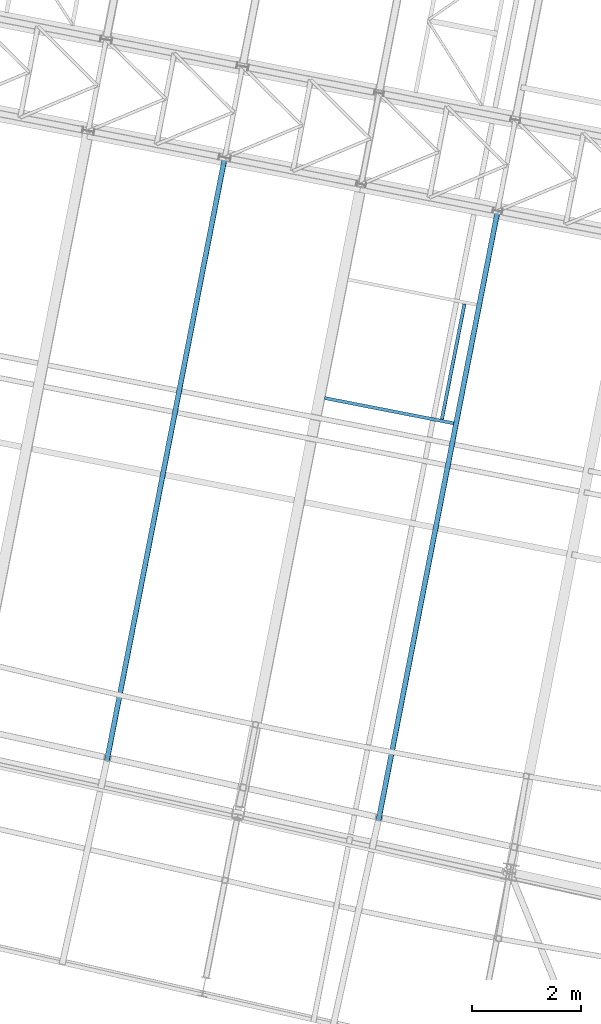
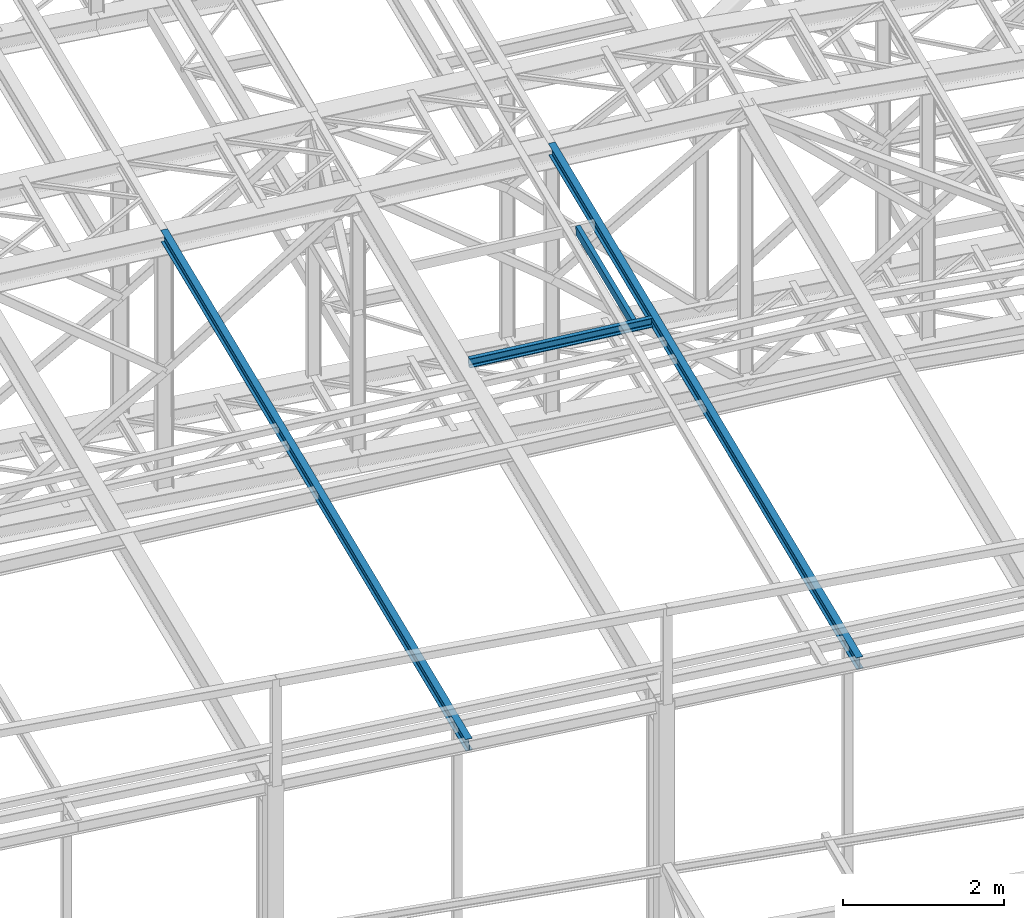
# One storey, part 38 of 215: 4 beams, 4 elements without a shape of their own.
"""IFC2X3 building model written with IfcOpenShell, lengths in millimetres."""

import ifcopenshell
import ifcopenshell.guid

model = None  # the IFC model being written
_history = None  # IfcOwnerHistory: only IFC2X3 demands one
_inside = {}  # id of a spatial element -> (the spatial element, [elements in it])
_under = {}  # id of a project, library or spatial element -> (it, [spatial elements below it])
_declared = {}  # id of a project -> (the project, [libraries it declares])
_typed = {}  # id of a type object -> (the type object, [elements of that type])
_made_of = {}  # id of a material, layer set ... -> (it, [elements and type objects made of it])


def new_model(schema):
    """Start an empty IFC model of exactly this schema.

    Asked for "IFC4X3", IfcOpenShell would pick the latest addendum, in which some entities
    have other attributes; the version numbers below select the first issue.
    IFC2X3 requires an IfcOwnerHistory on every rooted entity: one is made here for all.
    """
    global model, _history
    if schema == "IFC4X3":
        model = ifcopenshell.file(schema_version=(4, 3, 0, 0))
    else:
        model = ifcopenshell.file(schema=schema)
    _inside.clear()
    _under.clear()
    _declared.clear()
    _typed.clear()
    _made_of.clear()
    _history = None
    if model.schema == "IFC2X3":
        org = make("IfcOrganization", Name="unknown")
        user = make(
            "IfcPersonAndOrganization",
            ThePerson=make("IfcPerson", FamilyName="unknown"),
            TheOrganization=org,
        )
        app = make(
            "IfcApplication",
            ApplicationDeveloper=org,
            Version="unknown",
            ApplicationFullName="unknown",
            ApplicationIdentifier="unknown",
        )
        _history = make(
            "IfcOwnerHistory",
            OwningUser=user,
            OwningApplication=app,
            ChangeAction="ADDED",
            CreationDate=0,
        )
    return model


def make(cls, **values):
    """One entity of the class cls with the attributes given. An attribute that is None is left unset."""
    return model.create_entity(
        cls, **{name: value for name, value in values.items() if value is not None}
    )


def rooted(cls, **values):
    """An entity with a GlobalId (a new one), such as an element, a storey or a relation."""
    return make(cls, GlobalId=ifcopenshell.guid.new(), OwnerHistory=_history, **values)


def si_unit(unit_type, name, prefix=None):
    """IfcSIUnit, for example si_unit("LENGTHUNIT", "METRE", prefix="MILLI")."""
    return make("IfcSIUnit", UnitType=unit_type, Prefix=prefix, Name=name)


def assignment(units):
    """IfcUnitAssignment: the units of a project."""
    return None if units is None else make("IfcUnitAssignment", Units=units)


def point(xyz):
    """IfcCartesianPoint."""
    return None if xyz is None else make("IfcCartesianPoint", Coordinates=xyz)


def direction(xyz):
    """IfcDirection."""
    return None if xyz is None else make("IfcDirection", DirectionRatios=xyz)


def frame(location, z_axis=None, x_axis=None):
    """IfcAxis2Placement3D, a coordinate frame: its origin and axes. An axis left out is left unset."""
    return make(
        "IfcAxis2Placement3D",
        Location=point(location),
        Axis=direction(z_axis),
        RefDirection=direction(x_axis),
    )


def frame_2d(location, x_axis=None):
    """IfcAxis2Placement2D, a coordinate frame in the plane: its origin and x axis."""
    return make(
        "IfcAxis2Placement2D", Location=point(location), RefDirection=direction(x_axis)
    )


def origin_with_axes():
    """The frame at (0, 0, 0) with the z axis (0, 0, 1) and the x axis (1, 0, 0) written out."""
    return frame((0.0, 0.0, 0.0), z_axis=(0.0, 0.0, 1.0), x_axis=(1.0, 0.0, 0.0))


def origin_2d_with_axis():
    """The frame at (0, 0) in the plane with the x axis (1, 0) written out."""
    return frame_2d((0.0, 0.0), x_axis=(1.0, 0.0))


def place(relative_to, where):
    """IfcLocalPlacement: puts the frame where relative to a parent placement (None: the world)."""
    return make(
        "IfcLocalPlacement", PlacementRelTo=relative_to, RelativePlacement=where
    )


def context(
    kind, dimensions, precision=None, world=None, true_north=None, identifier=None
):
    """IfcGeometricRepresentationContext, for example the 3D "Model" context."""
    return make(
        "IfcGeometricRepresentationContext",
        ContextIdentifier=identifier,
        ContextType=kind,
        CoordinateSpaceDimension=dimensions,
        Precision=precision,
        WorldCoordinateSystem=world,
        TrueNorth=true_north,
    )


def subcontext(parent, identifier, kind, view, scale=None):
    """IfcGeometricRepresentationSubContext, for example "Body" below "Model"."""
    return make(
        "IfcGeometricRepresentationSubContext",
        ContextIdentifier=identifier,
        ContextType=kind,
        ParentContext=parent,
        TargetScale=scale,
        TargetView=view,
    )


def project(units=None, contexts=None):
    """IfcProject with its units and contexts."""
    return rooted(
        "IfcProject",
        Name="project",
        RepresentationContexts=contexts,
        UnitsInContext=assignment(units),
    )


def spatial(cls, under=None, at=None, **own):
    """A site, building, storey or space (cls), placed at a placement, below another one or the project."""
    s = rooted(cls, ObjectPlacement=at, **own)
    if under is not None:
        _under.setdefault(under.id(), (under, []))[1].append(s)
    return s


def profile(cls, at=None, kind="AREA", **sizes):
    """A parametric profile (cls). Its sizes go by their IFC names, for example OverallWidth=200.0."""
    return make(cls, ProfileType=kind, Position=at, **sizes)


def i_section(**sizes):
    """IfcIShapeProfileDef."""
    return profile("IfcIShapeProfileDef", **sizes)


def u_section(**sizes):
    """IfcUShapeProfileDef."""
    return profile("IfcUShapeProfileDef", **sizes)


def extrude(swept, where, along, depth):
    """IfcExtrudedAreaSolid: the profile swept, set in the frame where, extruded along a direction by depth."""
    return make(
        "IfcExtrudedAreaSolid",
        SweptArea=swept,
        Position=where,
        ExtrudedDirection=direction(along),
        Depth=depth,
    )


def shape(context_of_items, identifier, shape_type, items):
    """IfcShapeRepresentation: the items that make up one representation, for example the "Body"."""
    return make(
        "IfcShapeRepresentation",
        ContextOfItems=context_of_items,
        RepresentationIdentifier=identifier,
        RepresentationType=shape_type,
        Items=items,
    )


def material(Name=None, Category=None):
    """IfcMaterial."""
    return make("IfcMaterial", Name=Name, Category=Category)


def made_of(thing, what):
    """Note that an element or type object is made of a material, layer set ...; save() writes the relation."""
    if what is not None:
        _made_of.setdefault(what.id(), (what, []))[1].append(thing)
    return thing


def type_object(cls, material=None, **own):
    """A type object (cls), such as IfcWallType, which elements share."""
    return made_of(rooted(cls, **own), material)


def element(
    cls,
    number,
    at=None,
    inside=None,
    cuts=None,
    type_object=None,
    material=None,
    context=None,
    identifier="Body",
    shape_type=None,
    held_by="IfcProductDefinitionShape",
    body=None,
    shapes=None,
    **own,
):
    """One element of the class cls, such as IfcWall. Its Tag is "e" and its number.

    at: its placement. inside: the storey or other place that contains it. cuts: it is an
    opening in that element (IfcRelVoidsElement). A single representation is given by context,
    identifier, shape_type and body (its items); several are given by shapes. held_by: the class
    of the entity that holds the representations. save() writes the other relations.
    """
    e = rooted(cls, Tag="e%d" % number, ObjectPlacement=at, **own)
    if body is not None:
        shapes = [shape(context, identifier, shape_type, body)]
    if shapes is not None:
        e.Representation = make(held_by, Representations=shapes)
    if inside is not None:
        _inside.setdefault(inside.id(), (inside, []))[1].append(e)
    if cuts is not None:
        rooted(
            "IfcRelVoidsElement", RelatingBuildingElement=cuts, RelatedOpeningElement=e
        )
    if type_object is not None:
        _typed.setdefault(type_object.id(), (type_object, []))[1].append(e)
    return made_of(e, material)


def aggregate(whole, parts):
    """IfcRelAggregates: a whole, such as a stair, and the parts it consists of."""
    return rooted("IfcRelAggregates", RelatingObject=whole, RelatedObjects=parts)


def save(model, path):
    """Write the relations noted so far, then the file.

    IfcRelAggregates (storeys below a building ...), IfcRelContainedInSpatialStructure (elements
    in a storey), IfcRelDefinesByType, IfcRelAssociatesMaterial and IfcRelDeclares: one each for
    every whole, place, type object, material and project.
    """
    for whole, parts in _under.values():
        aggregate(whole, parts)
    for where, things in _inside.values():
        rooted(
            "IfcRelContainedInSpatialStructure",
            RelatedElements=things,
            RelatingStructure=where,
        )
    for kind, things in _typed.values():
        rooted("IfcRelDefinesByType", RelatedObjects=things, RelatingType=kind)
    for what, things in _made_of.values():
        rooted("IfcRelAssociatesMaterial", RelatedObjects=things, RelatingMaterial=what)
    for by, libraries in _declared.values():
        rooted("IfcRelDeclares", RelatingContext=by, RelatedDefinitions=libraries)
    model.write(path)


model = new_model("IFC2X3")

# Units and contexts
model_context = context("Model", 3, precision=1e-05, world=origin_with_axes())
body_context = subcontext(model_context, "Body", "Model", "MODEL_VIEW")
ifc_project = project(units=[si_unit("LENGTHUNIT", "METRE", prefix="MILLI"), si_unit("AREAUNIT", "SQUARE_METRE"), si_unit("VOLUMEUNIT", "CUBIC_METRE"), si_unit("MASSUNIT", "GRAM", prefix="KILO"), si_unit("TIMEUNIT", "SECOND"), si_unit("PLANEANGLEUNIT", "RADIAN"), si_unit("SOLIDANGLEUNIT", "STERADIAN"), si_unit("THERMODYNAMICTEMPERATUREUNIT", "DEGREE_CELSIUS"), si_unit("LUMINOUSINTENSITYUNIT", "LUMEN")], contexts=[model_context])

# Site, building, storey
site_placement = place(None, origin_with_axes())
site = spatial("IfcSite", under=ifc_project, at=site_placement, CompositionType="ELEMENT")
building_placement = place(site_placement, origin_with_axes())
building = spatial("IfcBuilding", under=site, at=building_placement, Name="Undefined", CompositionType="ELEMENT")
storey_placement = place(building_placement, origin_with_axes())
storey = spatial("IfcBuildingStorey", under=building, at=storey_placement, Name="Undefined", CompositionType="ELEMENT", Elevation=0.0)

# Assembly, beam
assembly_1_placement = place(storey_placement, origin_with_axes())
assembly_1 = element("IfcElementAssembly", 1, at=assembly_1_placement, inside=storey, Name="Steel Assembly", AssemblyPlace="NOTDEFINED", PredefinedType="RIGID_FRAME")
ifc_material_1 = material(Name="STEEL/S235JR")
beam_type_1 = type_object("IfcBeamType", Name="UPN140", PredefinedType="NOTDEFINED")
beam_1_placement = place(assembly_1_placement, frame((63682.7816235548, 14110.9364338774, 12762.6540019832), z_axis=(-0.0304080349967745, 0.00594450299936818, 0.999519891893966), x_axis=(0.191880718074391, 0.981418254380493, 4.40000000352173e-08)))
beam_1 = element("IfcBeam", 2, at=beam_1_placement, type_object=beam_type_1, material=ifc_material_1, ObjectType="UPN140", context=body_context, shape_type="SweptSolid", body=[
    extrude(u_section(Depth=140.0, FlangeWidth=60.0, WebThickness=7.0, FlangeThickness=10.0, FilletRadius=10.0, EdgeRadius=5.0, FlangeSlope=0.0798299857122373, at=origin_2d_with_axis()), frame((2150.00615829349, -2.69883202606534e-14, 1.81679079220833e-12), z_axis=(-1.0, 0.0, 0.0), x_axis=(-6.93889390390723e-18, -1.0, -3.46944695195361e-18)), (0.0, 0.0, 1.0), 2150.0),
])
aggregate(assembly_1, [beam_1])

assembly_2_placement = place(storey_placement, origin_with_axes())
assembly_2 = element("IfcElementAssembly", 3, at=assembly_2_placement, inside=storey, Name="Steel Assembly", AssemblyPlace="NOTDEFINED", PredefinedType="RIGID_FRAME")
beam_2_placement = place(assembly_2_placement, frame((61537.8334771869, 14499.7374318145, 12695.0866694522), z_axis=(-0.0304080349967745, 0.00594450299936818, 0.999519891893966), x_axis=(0.9809472788136, -0.191787511963556, 0.0309836479941128)))
beam_2 = element("IfcBeam", 4, at=beam_2_placement, type_object=beam_type_1, material=ifc_material_1, ObjectType="UPN140", context=body_context, shape_type="SweptSolid", body=[
    extrude(u_section(Depth=140.0, FlangeWidth=60.0, WebThickness=7.0, FlangeThickness=10.0, FilletRadius=10.0, EdgeRadius=5.0, FlangeSlope=0.0798299857122373, at=origin_2d_with_axis()), frame((2404.26547487024, -4.76208710676447e-14, 1.81898940354586e-12), z_axis=(-1.0, 0.0, 0.0), x_axis=(-6.93889390390723e-18, -1.0, -3.46944695195361e-18)), (0.0, 0.0, 1.0), 2404.3),
])
aggregate(assembly_2, [beam_2])

assembly_3_placement = place(storey_placement, origin_with_axes())
assembly_3 = element("IfcElementAssembly", 5, at=assembly_3_placement, inside=storey, Name="Steel Assembly", AssemblyPlace="NOTDEFINED", PredefinedType="RIGID_FRAME")
ifc_material_2 = material(Name="STEEL/S275JR")
beam_type_2 = type_object("IfcBeamType", Name="IPE180", PredefinedType="NOTDEFINED")
beam_3_placement = place(assembly_3_placement, frame((62444.991462516, 6370.43689493022, 12751.0069288025), z_axis=(-0.0304080349967745, 0.00594450299936818, 0.999519891893966), x_axis=(0.191859470081235, 0.981422408415534, 0.0)))
beam_3 = element("IfcBeam", 6, at=beam_3_placement, type_object=beam_type_2, material=ifc_material_2, ObjectType="IPE180", context=body_context, shape_type="SweptSolid", body=[
    extrude(i_section(OverallWidth=91.0, OverallDepth=180.0, WebThickness=5.300000191, FlangeThickness=8.0, FilletRadius=9.0, at=origin_2d_with_axis()), frame((11771.0426142771, -3.85018052108816e-14, -1.82335046270408e-12), z_axis=(-1.0, 0.0, 0.0), x_axis=(-6.93889390390723e-18, -1.0, -3.46944695195361e-18)), (0.0, 0.0, 1.0), 11771.0),
])
aggregate(assembly_3, [beam_3])

assembly_4_placement = place(storey_placement, origin_with_axes())
assembly_4 = element("IfcElementAssembly", 7, at=assembly_4_placement, inside=storey, Name="Steel Assembly", AssemblyPlace="NOTDEFINED", PredefinedType="RIGID_FRAME")
beam_4_placement = place(assembly_4_placement, frame((57474.7157031795, 7459.83912958891, 12593.3189459605), z_axis=(-0.0304080349967745, 0.00594450299936818, 0.999519891893966), x_axis=(0.191859470081235, 0.981422408415534, 0.0)))
beam_4 = element("IfcBeam", 8, at=beam_4_placement, type_object=beam_type_2, material=ifc_material_2, ObjectType="IPE180", context=body_context, shape_type="SweptSolid", body=[
    extrude(i_section(OverallWidth=91.0, OverallDepth=180.0, WebThickness=5.300000191, FlangeThickness=8.0, FilletRadius=9.0, at=origin_2d_with_axis()), frame((11655.4733588437, 7.24521827886603e-12, -1.00190966286292e-14), z_axis=(-1.0, 0.0, 0.0), x_axis=(-6.93889390390723e-18, -1.0, -3.46944695195361e-18)), (0.0, 0.0, 1.0), 11655.5),
])
aggregate(assembly_4, [beam_4])

save(model, "model.ifc")
